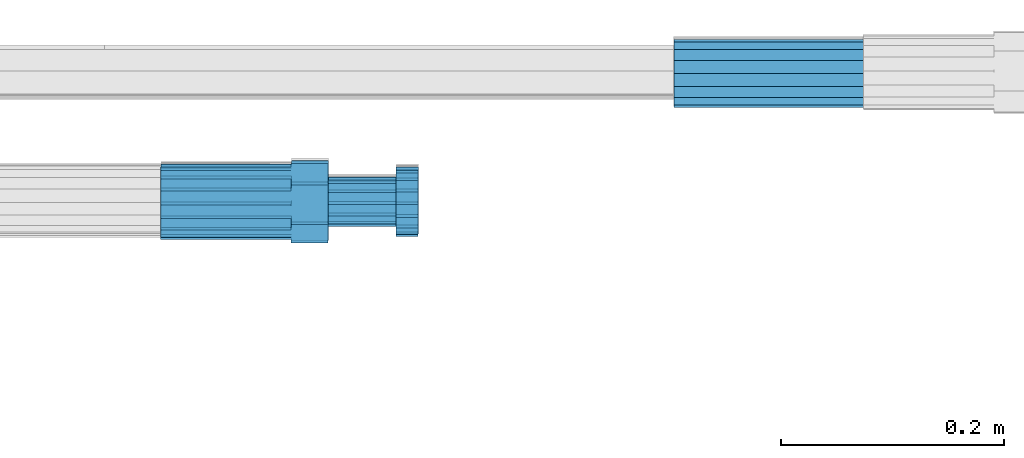
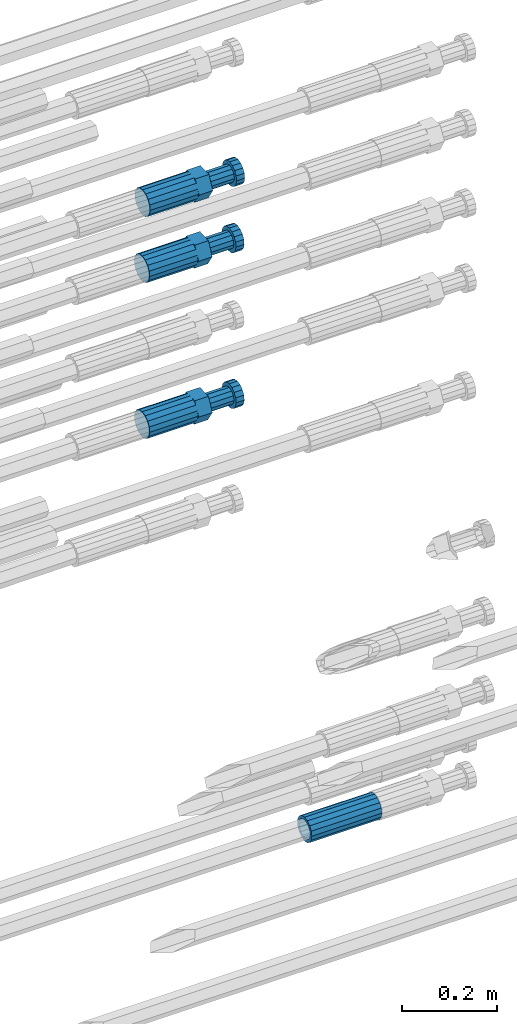
# One storey, part 112 of 177: 4 beams.
"""IFC2X3 building model written with IfcOpenShell, lengths in millimetres."""

from ifc_helpers import new_model, si_unit, frame, origin_with_axes, place, context, subcontext, project, spatial, faceted_brep, material, type_object, element, save


model = new_model("IFC2X3")

# Units and contexts
model_context_1 = context("Model", 3, precision=1e-05, world=origin_with_axes())
model_context_2 = context("Model", 3, precision=1e-05, world=origin_with_axes())
body_context = subcontext(model_context_2, "Body", "Model", "MODEL_VIEW")
ifc_project = project(units=[si_unit("LENGTHUNIT", "METRE", prefix="MILLI"), si_unit("AREAUNIT", "SQUARE_METRE"), si_unit("VOLUMEUNIT", "CUBIC_METRE"), si_unit("MASSUNIT", "GRAM", prefix="KILO"), si_unit("TIMEUNIT", "SECOND"), si_unit("PLANEANGLEUNIT", "RADIAN"), si_unit("SOLIDANGLEUNIT", "STERADIAN"), si_unit("THERMODYNAMICTEMPERATUREUNIT", "DEGREE_CELSIUS"), si_unit("LUMINOUSINTENSITYUNIT", "LUMEN")], contexts=[model_context_1])

# Site, building, storey
site_placement = place(None, origin_with_axes())
site = spatial("IfcSite", under=ifc_project, at=site_placement, CompositionType="ELEMENT")
building_placement = place(site_placement, origin_with_axes())
building = spatial("IfcBuilding", under=site, at=building_placement, Name="Undefined", CompositionType="ELEMENT")
storey_placement = place(building_placement, origin_with_axes())
storey = spatial("IfcBuildingStorey", under=building, at=storey_placement, Name="Undefined", CompositionType="ELEMENT", Elevation=0.0)

# Beams
ifc_material = material(Name="STEEL/S275")
beam_type_1 = type_object("IfcBeamType", PredefinedType="NOTDEFINED")
beam_1_placement = place(storey_placement, frame((2039349.52037948, 6206397.98588036, 18597.2968004173), z_axis=(0.0, 0.0, -1.0), x_axis=(1.0, 0.0, 0.0)))
element("IfcBeam", 1, at=beam_1_placement, inside=storey, type_object=beam_type_1, material=ifc_material, Name="AG40N", context=body_context, shape_type="Brep", body=[
    faceted_brep([(0.0, -23.5000000001164, -9.31322574615479e-10), (0.0, -21.7111690140155, 8.99306066054851), (170.0, -21.7111690140155, 8.99306066054851), (170.0, -23.5, 0.0), (0.0, -16.6170093578839, 16.6170093575493), (170.0, -16.6170093578839, 16.6170093575493), (0.0, -8.99306066057943, 21.7111690137535), (170.0, -8.99306066057943, 21.7111690137535), (0.0, 1.16415321826935e-10, 23.5), (170.0, 0.0, 23.5), (0.0, 8.99306066057943, 21.7111690137535), (170.0, 8.99306066057943, 21.7111690137535), (0.0, 16.6170093578839, 16.6170093575493), (170.0, 16.6170093578839, 16.6170093575493), (0.0, 21.7111690140155, 8.99306066054851), (170.0, 21.7111690140155, 8.99306066054851), (0.0, 23.5000000001164, -9.31322574615479e-10), (170.0, 23.5, 0.0), (0.0, 21.7111690140155, -8.99306066054851), (170.0, 21.7111690140155, -8.99306066054851), (0.0, 16.6170093578839, -16.6170093575493), (170.0, 16.6170093578839, -16.6170093575493), (0.0, 8.99306066057943, -21.7111690137535), (170.0, 8.99306066057943, -21.7111690137535), (0.0, 1.16415321826935e-10, -23.5000000009313), (170.0, 0.0, -23.5), (0.0, -8.99306066057943, -21.7111690137535), (170.0, -8.99306066057943, -21.7111690137535), (0.0, -16.6170093578839, -16.6170093575493), (170.0, -16.6170093578839, -16.6170093575493), (0.0, -21.7111690140155, -8.99306066054851), (170.0, -21.7111690140155, -8.99306066054851), (0.0, -30.5, 0.0), (0.0, -28.1783257415937, -11.6718446873128), (170.0, -28.1783257415937, -11.6718446873128), (170.0, -30.5, 0.0), (0.0, -21.5667568261888, -21.5667568258941), (170.0, -21.5667568261888, -21.5667568258941), (0.0, -11.6718446871346, -28.1783257415518), (170.0, -11.6718446871346, -28.1783257415518), (0.0, 0.0, -30.5), (170.0, 0.0, -30.5), (0.0, 11.6718446871346, -28.1783257415518), (170.0, 11.6718446871346, -28.1783257415518), (0.0, 21.5667568261888, -21.5667568258941), (170.0, 21.5667568261888, -21.5667568258941), (0.0, 28.1783257415937, -11.6718446873128), (170.0, 28.1783257415937, -11.6718446873128), (0.0, 30.5, 0.0), (170.0, 30.5, 0.0), (0.0, 28.1783257415937, 11.6718446873128), (170.0, 28.1783257415937, 11.6718446873128), (0.0, 21.5667568261888, 21.5667568258941), (170.0, 21.5667568261888, 21.5667568258941), (0.0, 11.6718446871346, 28.1783257415518), (170.0, 11.6718446871346, 28.1783257415518), (0.0, 0.0, 30.5), (170.0, 0.0, 30.5), (0.0, -11.6718446871346, 28.1783257415518), (170.0, -11.6718446871346, 28.1783257415518), (0.0, -21.5667568261888, 21.5667568258941), (170.0, -21.5667568261888, 21.5667568258941), (0.0, -28.1783257415937, 11.6718446873128), (170.0, -28.1783257415937, 11.6718446873128)], [[[0, 1, 2, 3]], [[1, 4, 5, 2]], [[4, 6, 7, 5]], [[6, 8, 9, 7]], [[8, 10, 11, 9]], [[10, 12, 13, 11]], [[12, 14, 15, 13]], [[14, 16, 17, 15]], [[16, 18, 19, 17]], [[18, 20, 21, 19]], [[20, 22, 23, 21]], [[22, 24, 25, 23]], [[24, 26, 27, 25]], [[26, 28, 29, 27]], [[28, 30, 31, 29]], [[30, 0, 3, 31]], [[32, 33, 34, 35]], [[33, 36, 37, 34]], [[36, 38, 39, 37]], [[38, 40, 41, 39]], [[40, 42, 43, 41]], [[42, 44, 45, 43]], [[44, 46, 47, 45]], [[46, 48, 49, 47]], [[48, 50, 51, 49]], [[50, 52, 53, 51]], [[52, 54, 55, 53]], [[54, 56, 57, 55]], [[56, 58, 59, 57]], [[58, 60, 61, 59]], [[60, 62, 63, 61]], [[62, 32, 35, 63]], [[37, 39, 41, 43, 45, 47, 49, 51, 53, 55, 57, 59, 61, 63, 35, 34], [5, 7, 9, 11, 13, 15, 17, 19, 21, 23, 25, 27, 29, 31, 3, 2]], [[62, 60, 58, 56, 54, 52, 50, 48, 46, 44, 42, 40, 38, 36, 33, 32], [30, 28, 26, 24, 22, 20, 18, 16, 14, 12, 10, 8, 6, 4, 1, 0]]]),
])
beam_type_2 = type_object("IfcBeamType", Name="ROD65", PredefinedType="NOTDEFINED")
beam_2_placement = place(storey_placement, frame((2038889.27258827, 6206281.68544386, 20436.3625484143), z_axis=(0.00101999019715003, 0.0419084800034758, -0.999120933082575), x_axis=(0.999999429542936, 0.000274046000794836, 0.00103238199952223)))
element("IfcBeam", 2, at=beam_2_placement, inside=storey, type_object=beam_type_2, material=ifc_material, Name="AGB40", ObjectType="ROD65", context=body_context, shape_type="Brep", body=[
    faceted_brep([(117.0, 8.17543110251427, 30.873805644922), (117.0, 17.8250000001863, 30.873805644922), (117.0, 22.0056958701462, 23.6326279877685), (117.0, 12.4372115517035, 30.0260848065373), (117.0, -17.8250000001863, 30.873805644922), (150.200000000186, -17.8250000001863, 30.873805644922), (150.200000000186, 17.8250000001863, 30.873805644922), (117.0, -8.17543110251427, 30.873805644922), (117.0, -12.4372115517035, 30.0260848065373), (117.0, -22.0056958701462, 23.6326279877685), (117.0, -35.6500000003725, 0.0), (150.200000000186, -35.6500000003725, 0.0), (117.0, -30.8443150008097, 8.32369058486074), (117.0, -32.5, 0.0), (117.0, -30.8443150008097, -8.32369058462791), (117.0, -17.8250000001863, -30.873805644922), (150.200000000186, -17.8250000001863, -30.873805644922), (117.0, -22.0056958701462, -23.6326279877685), (117.0, -12.4372115517035, -30.0260848065373), (117.0, -8.17543110251427, -30.873805644922), (117.0, 17.8250000001863, -30.873805644922), (150.200000000186, 17.8250000001863, -30.873805644922), (117.0, 8.17543110251427, -30.873805644922), (117.0, 22.0056958701462, -23.6326279877685), (117.0, 12.4372115517035, -30.0260848065373), (117.0, 35.6500000003725, 0.0), (150.200000000186, 35.6500000003725, 0.0), (117.0, 30.8443150008097, -8.32369058486074), (117.0, 30.8443150008097, 8.32369058462791), (117.0, 32.5, 0.0), (0.0, -22.9809703892097, 22.9809703885621), (0.0, -30.0260848058388, 12.4372115518636), (117.0, -30.0260848067701, 12.4372115519363), (117.0, -22.9809703882784, 22.9809703885112), (-2.3283064365387e-10, 22.9809703892097, -22.9809703885639), (-4.65661287307739e-10, 30.0260848077014, -12.4372115518672), (117.0, 30.0260848067701, -12.4372115519363), (117.0, 22.9809703882784, -22.9809703885112), (-2.3283064365387e-10, -30.0260848067701, -12.4372115518672), (-2.3283064365387e-10, -22.9809703892097, -22.9809703885621), (117.0, -22.9809703882784, -22.9809703885112), (117.0, -30.0260848067701, -12.4372115519363), (-2.3283064365387e-10, -12.4372115507722, 30.0260848066137), (-2.3283064365387e-10, 9.31322574615479e-10, 32.4999999999982), (-2.3283064365387e-10, 12.4372115526348, 30.0260848066137), (0.0, 22.9809703892097, 22.9809703885621), (-2.3283064365387e-10, 30.0260848077014, 12.4372115518636), (-2.3283064365387e-10, 32.5, 0.0), (-2.3283064365387e-10, 12.4372115526348, -30.0260848066173), (-2.3283064365387e-10, 9.31322574615479e-10, -32.5), (-2.3283064365387e-10, -12.4372115517035, -30.0260848066173), (-4.65661287307739e-10, -32.4999999990687, -1.81898940354586e-12), (117.0, 22.9809703882784, 22.9809703885112), (117.0, 30.0260848067701, 12.4372115519363), (117.0, 0.0, -32.5), (117.0, 0.0, 32.5), (150.200000000186, 10.5, -18.1865334794857), (150.200000000186, 0.0, -21.0), (150.200000000186, -10.5, -18.1865334794857), (150.200000000186, -18.18653347902, -10.5), (150.200000000186, -21.0, 0.0), (150.200000000186, -18.18653347902, 10.5), (150.200000000186, -10.5, 18.1865334794857), (150.200000000186, 0.0, 21.0), (150.200000000186, 10.5, 18.1865334794857), (150.200000000186, 18.18653347902, 10.5), (150.200000000186, 21.0, 0.0), (150.200000000186, 18.18653347902, -10.5), (210.980000000447, -18.18653347902, 10.5), (210.980000000447, -21.0, 0.0), (210.980000000447, -10.5, 18.1865334794857), (210.980000000447, 0.0, 21.0), (210.980000000447, 10.5, 18.1865334794857), (210.980000000447, 18.18653347902, 10.5), (210.980000000447, 21.0, 0.0), (210.980000000447, 18.18653347902, -10.5), (210.980000000447, 10.5, -18.1865334794857), (210.980000000447, 0.0, -21.0), (210.980000000447, -10.5, -18.1865334794857), (210.980000000447, -18.18653347902, -10.5), (211.001368442696, -27.7269937992096, -11.491116326768), (211.003082550167, -21.2238094303757, -21.223815418547), (231.002518367059, -21.2131944671273, -21.2132004550658), (231.000804259587, -27.7163788359612, -11.4805013632867), (211.001368440451, -11.4911085031927, -27.7269970395137), (231.000804257343, -11.4804935399443, -27.7163820760325), (210.996487071217, -0.0106065049767494, -30.0106107392348), (230.995922888109, 8.45827162265778e-06, -29.9999957757536), (210.989181586672, 11.46989420522, -27.7269970329944), (230.988617403564, 11.4805091684684, -27.7163820695132), (210.980564180623, 21.2025914648548, -21.2238154064398), (230.979999997515, 21.2132064281031, -21.2132004429586), (210.971946775022, 27.7057703435421, -11.4911163107026), (230.971382591913, 27.7163853067905, -11.4805013472214), (210.96464129175, 29.9893808094785, -0.0106149562634528), (230.964077108642, 29.9999957727268, 7.21774995326996e-09), (210.959759924415, 27.7057638689876, 11.4698863970116), (230.959195741307, 27.7163788322359, 11.4805013604928), (210.958045816944, 21.2025795001537, 21.2025854887906), (230.957481633835, 21.213194463402, 21.2132004522718), (210.95975992666, 11.4698785729706, 27.7057671097573), (230.959195743551, 11.480493536219, 27.7163820732385), (210.964641295894, -0.010623425245285, 29.9893808094785), (230.964077112785, -8.46199691295624e-06, 29.9999957729597), (210.971946780439, -11.4911241354421, 27.705767103238), (230.97138259733, -11.4805091721937, 27.7163820667192), (210.980564186488, -21.2238213950768, 21.2025854766835), (230.980000003379, -21.2132064318284, 21.2132004401647), (210.989181592089, -27.7270002737641, 11.4698863809463), (230.988617408981, -27.7163853105158, 11.4805013444275), (210.996487075361, -30.0106107397005, -0.0106149734929204), (230.995922892253, -29.9999957764521, -1.00117176771164e-08)], [[[0, 1, 2, 3]], [[4, 5, 6, 1, 0, 7]], [[4, 7, 8, 9]], [[10, 11, 5, 4, 9, 12]], [[10, 12, 13, 14]], [[15, 16, 11, 10, 14, 17]], [[15, 17, 18, 19]], [[20, 21, 16, 15, 19, 22]], [[23, 20, 22, 24]], [[25, 26, 21, 20, 23, 27]], [[28, 25, 27, 29]], [[30, 31, 32, 33]], [[34, 35, 36, 37]], [[38, 39, 40, 41]], [[31, 30, 42, 43, 44, 45, 46, 47, 35, 34, 48, 49, 50, 39, 38, 51]], [[46, 45, 52, 53]], [[29, 47, 46, 53, 28]], [[27, 36, 35, 47, 29]], [[23, 37, 36, 27]], [[24, 48, 34, 37, 23]], [[22, 54, 49, 48, 24]], [[19, 54, 22]], [[18, 50, 49, 54, 19]], [[17, 40, 39, 50, 18]], [[14, 41, 40, 17]], [[13, 51, 38, 41, 14]], [[12, 32, 31, 51, 13]], [[9, 33, 32, 12]], [[8, 42, 30, 33, 9]], [[7, 55, 43, 42, 8]], [[0, 55, 7]], [[3, 44, 43, 55, 0]], [[2, 52, 45, 44, 3]], [[28, 53, 52, 2]], [[1, 6, 26, 25, 28, 2]], [[5, 11, 16, 21, 26, 6], [56, 57, 58, 59, 60, 61, 62, 63, 64, 65, 66, 67]], [[68, 61, 60, 69]], [[70, 62, 61, 68]], [[71, 63, 62, 70]], [[72, 64, 63, 71]], [[73, 65, 64, 72]], [[74, 66, 65, 73]], [[75, 67, 66, 74]], [[76, 56, 67, 75]], [[77, 57, 56, 76]], [[78, 58, 57, 77]], [[79, 59, 58, 78]], [[69, 60, 59, 79]], [[80, 81, 82, 83]], [[81, 84, 85, 82]], [[84, 86, 87, 85]], [[86, 88, 89, 87]], [[88, 90, 91, 89]], [[90, 92, 93, 91]], [[92, 94, 95, 93]], [[94, 96, 97, 95]], [[96, 98, 99, 97]], [[98, 100, 101, 99]], [[100, 102, 103, 101]], [[102, 104, 105, 103]], [[104, 106, 107, 105]], [[106, 108, 109, 107]], [[108, 110, 111, 109]], [[82, 85, 87, 89, 91, 93, 95, 97, 99, 101, 103, 105, 107, 109, 111, 83]], [[110, 80, 83, 111]], [[108, 106, 104, 102, 100, 98, 96, 94, 92, 90, 88, 86, 84, 81, 80, 110], [75, 74, 73, 72, 71, 70, 68, 69, 79, 78, 77, 76]]]),
])
beam_3_placement = place(storey_placement, frame((2038889.51584447, 6206284.40860386, 20265.4445927412), z_axis=(0.0, 0.0523359569851309, -0.998629534715678), x_axis=(1.0, 0.0, 0.0)))
element("IfcBeam", 3, at=beam_3_placement, inside=storey, type_object=beam_type_2, material=ifc_material, Name="AGB40", ObjectType="ROD65", context=body_context, shape_type="Brep", body=[
    faceted_brep([(117.0, 8.17543110251427, 30.873805644922), (117.0, 17.8250000001863, 30.873805644922), (117.0, 22.0056958701462, 23.6326279877685), (117.0, 12.4372115517035, 30.0260848065373), (117.0, -17.8250000001863, 30.873805644922), (150.200000000186, -17.8250000001863, 30.873805644922), (150.200000000186, 17.8250000001863, 30.873805644922), (117.0, -8.17543110251427, 30.873805644922), (117.0, -12.4372115517035, 30.0260848065373), (117.0, -22.0056958701462, 23.6326279877685), (117.0, -35.6500000003725, 0.0), (150.200000000186, -35.6500000003725, 0.0), (117.0, -30.8443150008097, 8.32369058486074), (117.0, -32.5, 0.0), (117.0, -30.8443150008097, -8.32369058462791), (117.0, -17.8250000001863, -30.873805644922), (150.200000000186, -17.8250000001863, -30.873805644922), (117.0, -22.0056958701462, -23.6326279877685), (117.0, -12.4372115517035, -30.0260848065373), (117.0, -8.17543110251427, -30.873805644922), (117.0, 17.8250000001863, -30.873805644922), (150.200000000186, 17.8250000001863, -30.873805644922), (117.0, 8.17543110251427, -30.873805644922), (117.0, 22.0056958701462, -23.6326279877685), (117.0, 12.4372115517035, -30.0260848065373), (117.0, 35.6500000003725, 0.0), (150.200000000186, 35.6500000003725, 0.0), (117.0, 30.8443150008097, -8.32369058486074), (117.0, 30.8443150008097, 8.32369058462791), (117.0, 32.5, 0.0), (0.0, -22.9809703892097, 22.9809703885621), (0.0, -30.0260848058388, 12.4372115518636), (117.0, -30.0260848067701, 12.4372115519363), (117.0, -22.9809703882784, 22.9809703885112), (-2.3283064365387e-10, 22.9809703892097, -22.9809703885639), (-4.65661287307739e-10, 30.0260848077014, -12.4372115518672), (117.0, 30.0260848067701, -12.4372115519363), (117.0, 22.9809703882784, -22.9809703885112), (-2.3283064365387e-10, -30.0260848067701, -12.4372115518672), (-2.3283064365387e-10, -22.9809703892097, -22.9809703885621), (117.0, -22.9809703882784, -22.9809703885112), (117.0, -30.0260848067701, -12.4372115519363), (-2.3283064365387e-10, -12.4372115507722, 30.0260848066137), (-2.3283064365387e-10, 9.31322574615479e-10, 32.4999999999982), (-2.3283064365387e-10, 12.4372115526348, 30.0260848066137), (0.0, 22.9809703892097, 22.9809703885621), (-2.3283064365387e-10, 30.0260848077014, 12.4372115518636), (-2.3283064365387e-10, 32.5, 0.0), (-2.3283064365387e-10, 12.4372115526348, -30.0260848066173), (-2.3283064365387e-10, 9.31322574615479e-10, -32.5), (-2.3283064365387e-10, -12.4372115517035, -30.0260848066173), (-4.65661287307739e-10, -32.4999999990687, -1.81898940354586e-12), (117.0, 22.9809703882784, 22.9809703885112), (117.0, 30.0260848067701, 12.4372115519363), (117.0, 0.0, -32.5), (117.0, 0.0, 32.5), (150.200000000186, 10.5, -18.1865334794857), (150.200000000186, 0.0, -21.0), (150.200000000186, -10.5, -18.1865334794857), (150.200000000186, -18.18653347902, -10.5), (150.200000000186, -21.0, 0.0), (150.200000000186, -18.18653347902, 10.5), (150.200000000186, -10.5, 18.1865334794857), (150.200000000186, 0.0, 21.0), (150.200000000186, 10.5, 18.1865334794857), (150.200000000186, 18.18653347902, 10.5), (150.200000000186, 21.0, 0.0), (150.200000000186, 18.18653347902, -10.5), (210.980000000447, -18.18653347902, 10.5), (210.980000000447, -21.0, 0.0), (210.980000000447, -10.5, 18.1865334794857), (210.980000000447, 0.0, 21.0), (210.980000000447, 10.5, 18.1865334794857), (210.980000000447, 18.18653347902, 10.5), (210.980000000447, 21.0, 0.0), (210.980000000447, 18.18653347902, -10.5), (210.980000000447, 10.5, -18.1865334794857), (210.980000000447, 0.0, -21.0), (210.980000000447, -10.5, -18.1865334794857), (210.980000000447, -18.18653347902, -10.5), (211.001368442696, -27.7269937992096, -11.491116326768), (211.003082550167, -21.2238094303757, -21.223815418547), (231.002518367059, -21.2131944671273, -21.2132004550658), (231.000804259587, -27.7163788359612, -11.4805013632867), (211.001368440451, -11.4911085031927, -27.7269970395137), (231.000804257343, -11.4804935399443, -27.7163820760325), (210.996487071217, -0.0106065049767494, -30.0106107392348), (230.995922888109, 8.45827162265778e-06, -29.9999957757536), (210.989181586672, 11.46989420522, -27.7269970329944), (230.988617403564, 11.4805091684684, -27.7163820695132), (210.980564180623, 21.2025914648548, -21.2238154064398), (230.979999997515, 21.2132064281031, -21.2132004429586), (210.971946775022, 27.7057703435421, -11.4911163107026), (230.971382591913, 27.7163853067905, -11.4805013472214), (210.96464129175, 29.9893808094785, -0.0106149562634528), (230.964077108642, 29.9999957727268, 7.21774995326996e-09), (210.959759924415, 27.7057638689876, 11.4698863970116), (230.959195741307, 27.7163788322359, 11.4805013604928), (210.958045816944, 21.2025795001537, 21.2025854887906), (230.957481633835, 21.213194463402, 21.2132004522718), (210.95975992666, 11.4698785729706, 27.7057671097573), (230.959195743551, 11.480493536219, 27.7163820732385), (210.964641295894, -0.010623425245285, 29.9893808094785), (230.964077112785, -8.46199691295624e-06, 29.9999957729597), (210.971946780439, -11.4911241354421, 27.705767103238), (230.97138259733, -11.4805091721937, 27.7163820667192), (210.980564186488, -21.2238213950768, 21.2025854766835), (230.980000003379, -21.2132064318284, 21.2132004401647), (210.989181592089, -27.7270002737641, 11.4698863809463), (230.988617408981, -27.7163853105158, 11.4805013444275), (210.996487075361, -30.0106107397005, -0.0106149734929204), (230.995922892253, -29.9999957764521, -1.00117176771164e-08)], [[[0, 1, 2, 3]], [[4, 5, 6, 1, 0, 7]], [[4, 7, 8, 9]], [[10, 11, 5, 4, 9, 12]], [[10, 12, 13, 14]], [[15, 16, 11, 10, 14, 17]], [[15, 17, 18, 19]], [[20, 21, 16, 15, 19, 22]], [[23, 20, 22, 24]], [[25, 26, 21, 20, 23, 27]], [[28, 25, 27, 29]], [[30, 31, 32, 33]], [[34, 35, 36, 37]], [[38, 39, 40, 41]], [[31, 30, 42, 43, 44, 45, 46, 47, 35, 34, 48, 49, 50, 39, 38, 51]], [[46, 45, 52, 53]], [[29, 47, 46, 53, 28]], [[27, 36, 35, 47, 29]], [[23, 37, 36, 27]], [[24, 48, 34, 37, 23]], [[22, 54, 49, 48, 24]], [[19, 54, 22]], [[18, 50, 49, 54, 19]], [[17, 40, 39, 50, 18]], [[14, 41, 40, 17]], [[13, 51, 38, 41, 14]], [[12, 32, 31, 51, 13]], [[9, 33, 32, 12]], [[8, 42, 30, 33, 9]], [[7, 55, 43, 42, 8]], [[0, 55, 7]], [[3, 44, 43, 55, 0]], [[2, 52, 45, 44, 3]], [[28, 53, 52, 2]], [[1, 6, 26, 25, 28, 2]], [[5, 11, 16, 21, 26, 6], [56, 57, 58, 59, 60, 61, 62, 63, 64, 65, 66, 67]], [[68, 61, 60, 69]], [[70, 62, 61, 68]], [[71, 63, 62, 70]], [[72, 64, 63, 71]], [[73, 65, 64, 72]], [[74, 66, 65, 73]], [[75, 67, 66, 74]], [[76, 56, 67, 75]], [[77, 57, 56, 76]], [[78, 58, 57, 77]], [[79, 59, 58, 78]], [[69, 60, 59, 79]], [[80, 81, 82, 83]], [[81, 84, 85, 82]], [[84, 86, 87, 85]], [[86, 88, 89, 87]], [[88, 90, 91, 89]], [[90, 92, 93, 91]], [[92, 94, 95, 93]], [[94, 96, 97, 95]], [[96, 98, 99, 97]], [[98, 100, 101, 99]], [[100, 102, 103, 101]], [[102, 104, 105, 103]], [[104, 106, 107, 105]], [[106, 108, 109, 107]], [[108, 110, 111, 109]], [[82, 85, 87, 89, 91, 93, 95, 97, 99, 101, 103, 105, 107, 109, 111, 83]], [[110, 80, 83, 111]], [[108, 106, 104, 102, 100, 98, 96, 94, 92, 90, 88, 86, 84, 81, 80, 110], [75, 74, 73, 72, 71, 70, 68, 69, 79, 78, 77, 76]]]),
])
beam_4_placement = place(storey_placement, frame((2038889.51584447, 6206284.09877293, 19865.9276902428), z_axis=(0.0, 0.0401317930035295, -0.99919439509553), x_axis=(1.0, 0.0, 0.0)))
element("IfcBeam", 4, at=beam_4_placement, inside=storey, type_object=beam_type_2, material=ifc_material, Name="AGB40", ObjectType="ROD65", context=body_context, shape_type="Brep", body=[
    faceted_brep([(117.0, 8.17543110251427, 30.873805644922), (117.0, 17.8250000001863, 30.873805644922), (117.0, 22.0056958701462, 23.6326279877685), (117.0, 12.4372115517035, 30.0260848065373), (117.0, -17.8250000001863, 30.873805644922), (150.200000000186, -17.8250000001863, 30.873805644922), (150.200000000186, 17.8250000001863, 30.873805644922), (117.0, -8.17543110251427, 30.873805644922), (117.0, -12.4372115517035, 30.0260848065373), (117.0, -22.0056958701462, 23.6326279877685), (117.0, -35.6500000003725, 0.0), (150.200000000186, -35.6500000003725, 0.0), (117.0, -30.8443150008097, 8.32369058486074), (117.0, -32.5, 0.0), (117.0, -30.8443150008097, -8.32369058462791), (117.0, -17.8250000001863, -30.873805644922), (150.200000000186, -17.8250000001863, -30.873805644922), (117.0, -22.0056958701462, -23.6326279877685), (117.0, -12.4372115517035, -30.0260848065373), (117.0, -8.17543110251427, -30.873805644922), (117.0, 17.8250000001863, -30.873805644922), (150.200000000186, 17.8250000001863, -30.873805644922), (117.0, 8.17543110251427, -30.873805644922), (117.0, 22.0056958701462, -23.6326279877685), (117.0, 12.4372115517035, -30.0260848065373), (117.0, 35.6500000003725, 0.0), (150.200000000186, 35.6500000003725, 0.0), (117.0, 30.8443150008097, -8.32369058486074), (117.0, 30.8443150008097, 8.32369058462791), (117.0, 32.5, 0.0), (0.0, -22.9809703892097, 22.9809703885621), (0.0, -30.0260848058388, 12.4372115518636), (117.0, -30.0260848067701, 12.4372115519363), (117.0, -22.9809703882784, 22.9809703885112), (-2.3283064365387e-10, 22.9809703892097, -22.9809703885639), (-4.65661287307739e-10, 30.0260848077014, -12.4372115518672), (117.0, 30.0260848067701, -12.4372115519363), (117.0, 22.9809703882784, -22.9809703885112), (-2.3283064365387e-10, -30.0260848067701, -12.4372115518672), (-2.3283064365387e-10, -22.9809703892097, -22.9809703885621), (117.0, -22.9809703882784, -22.9809703885112), (117.0, -30.0260848067701, -12.4372115519363), (-2.3283064365387e-10, -12.4372115507722, 30.0260848066137), (-2.3283064365387e-10, 9.31322574615479e-10, 32.4999999999982), (-2.3283064365387e-10, 12.4372115526348, 30.0260848066137), (0.0, 22.9809703892097, 22.9809703885621), (-2.3283064365387e-10, 30.0260848077014, 12.4372115518636), (-2.3283064365387e-10, 32.5, 0.0), (-2.3283064365387e-10, 12.4372115526348, -30.0260848066173), (-2.3283064365387e-10, 9.31322574615479e-10, -32.5), (-2.3283064365387e-10, -12.4372115517035, -30.0260848066173), (-4.65661287307739e-10, -32.4999999990687, -1.81898940354586e-12), (117.0, 22.9809703882784, 22.9809703885112), (117.0, 30.0260848067701, 12.4372115519363), (117.0, 0.0, -32.5), (117.0, 0.0, 32.5), (150.200000000186, 10.5, -18.1865334794857), (150.200000000186, 0.0, -21.0), (150.200000000186, -10.5, -18.1865334794857), (150.200000000186, -18.18653347902, -10.5), (150.200000000186, -21.0, 0.0), (150.200000000186, -18.18653347902, 10.5), (150.200000000186, -10.5, 18.1865334794857), (150.200000000186, 0.0, 21.0), (150.200000000186, 10.5, 18.1865334794857), (150.200000000186, 18.18653347902, 10.5), (150.200000000186, 21.0, 0.0), (150.200000000186, 18.18653347902, -10.5), (210.980000000447, -18.18653347902, 10.5), (210.980000000447, -21.0, 0.0), (210.980000000447, -10.5, 18.1865334794857), (210.980000000447, 0.0, 21.0), (210.980000000447, 10.5, 18.1865334794857), (210.980000000447, 18.18653347902, 10.5), (210.980000000447, 21.0, 0.0), (210.980000000447, 18.18653347902, -10.5), (210.980000000447, 10.5, -18.1865334794857), (210.980000000447, 0.0, -21.0), (210.980000000447, -10.5, -18.1865334794857), (210.980000000447, -18.18653347902, -10.5), (211.001368442696, -27.7269937992096, -11.491116326768), (211.003082550167, -21.2238094303757, -21.223815418547), (231.002518367059, -21.2131944671273, -21.2132004550658), (231.000804259587, -27.7163788359612, -11.4805013632867), (211.001368440451, -11.4911085031927, -27.7269970395137), (231.000804257343, -11.4804935399443, -27.7163820760325), (210.996487071217, -0.0106065049767494, -30.0106107392348), (230.995922888109, 8.45827162265778e-06, -29.9999957757536), (210.989181586672, 11.46989420522, -27.7269970329944), (230.988617403564, 11.4805091684684, -27.7163820695132), (210.980564180623, 21.2025914648548, -21.2238154064398), (230.979999997515, 21.2132064281031, -21.2132004429586), (210.971946775022, 27.7057703435421, -11.4911163107026), (230.971382591913, 27.7163853067905, -11.4805013472214), (210.96464129175, 29.9893808094785, -0.0106149562634528), (230.964077108642, 29.9999957727268, 7.21774995326996e-09), (210.959759924415, 27.7057638689876, 11.4698863970116), (230.959195741307, 27.7163788322359, 11.4805013604928), (210.958045816944, 21.2025795001537, 21.2025854887906), (230.957481633835, 21.213194463402, 21.2132004522718), (210.95975992666, 11.4698785729706, 27.7057671097573), (230.959195743551, 11.480493536219, 27.7163820732385), (210.964641295894, -0.010623425245285, 29.9893808094785), (230.964077112785, -8.46199691295624e-06, 29.9999957729597), (210.971946780439, -11.4911241354421, 27.705767103238), (230.97138259733, -11.4805091721937, 27.7163820667192), (210.980564186488, -21.2238213950768, 21.2025854766835), (230.980000003379, -21.2132064318284, 21.2132004401647), (210.989181592089, -27.7270002737641, 11.4698863809463), (230.988617408981, -27.7163853105158, 11.4805013444275), (210.996487075361, -30.0106107397005, -0.0106149734929204), (230.995922892253, -29.9999957764521, -1.00117176771164e-08)], [[[0, 1, 2, 3]], [[4, 5, 6, 1, 0, 7]], [[4, 7, 8, 9]], [[10, 11, 5, 4, 9, 12]], [[10, 12, 13, 14]], [[15, 16, 11, 10, 14, 17]], [[15, 17, 18, 19]], [[20, 21, 16, 15, 19, 22]], [[23, 20, 22, 24]], [[25, 26, 21, 20, 23, 27]], [[28, 25, 27, 29]], [[30, 31, 32, 33]], [[34, 35, 36, 37]], [[38, 39, 40, 41]], [[31, 30, 42, 43, 44, 45, 46, 47, 35, 34, 48, 49, 50, 39, 38, 51]], [[46, 45, 52, 53]], [[29, 47, 46, 53, 28]], [[27, 36, 35, 47, 29]], [[23, 37, 36, 27]], [[24, 48, 34, 37, 23]], [[22, 54, 49, 48, 24]], [[19, 54, 22]], [[18, 50, 49, 54, 19]], [[17, 40, 39, 50, 18]], [[14, 41, 40, 17]], [[13, 51, 38, 41, 14]], [[12, 32, 31, 51, 13]], [[9, 33, 32, 12]], [[8, 42, 30, 33, 9]], [[7, 55, 43, 42, 8]], [[0, 55, 7]], [[3, 44, 43, 55, 0]], [[2, 52, 45, 44, 3]], [[28, 53, 52, 2]], [[1, 6, 26, 25, 28, 2]], [[5, 11, 16, 21, 26, 6], [56, 57, 58, 59, 60, 61, 62, 63, 64, 65, 66, 67]], [[68, 61, 60, 69]], [[70, 62, 61, 68]], [[71, 63, 62, 70]], [[72, 64, 63, 71]], [[73, 65, 64, 72]], [[74, 66, 65, 73]], [[75, 67, 66, 74]], [[76, 56, 67, 75]], [[77, 57, 56, 76]], [[78, 58, 57, 77]], [[79, 59, 58, 78]], [[69, 60, 59, 79]], [[80, 81, 82, 83]], [[81, 84, 85, 82]], [[84, 86, 87, 85]], [[86, 88, 89, 87]], [[88, 90, 91, 89]], [[90, 92, 93, 91]], [[92, 94, 95, 93]], [[94, 96, 97, 95]], [[96, 98, 99, 97]], [[98, 100, 101, 99]], [[100, 102, 103, 101]], [[102, 104, 105, 103]], [[104, 106, 107, 105]], [[106, 108, 109, 107]], [[108, 110, 111, 109]], [[82, 85, 87, 89, 91, 93, 95, 97, 99, 101, 103, 105, 107, 109, 111, 83]], [[110, 80, 83, 111]], [[108, 106, 104, 102, 100, 98, 96, 94, 92, 90, 88, 86, 84, 81, 80, 110], [75, 74, 73, 72, 71, 70, 68, 69, 79, 78, 77, 76]]]),
])

save(model, "model.ifc")
